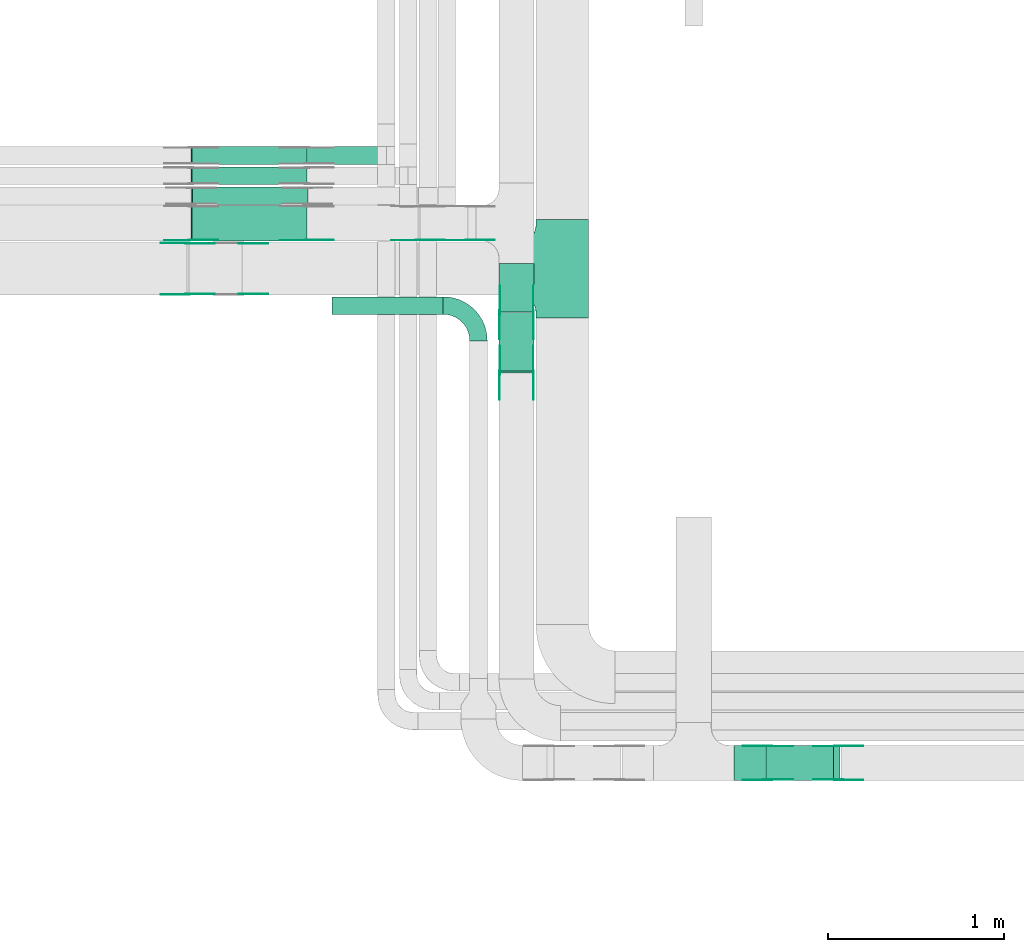
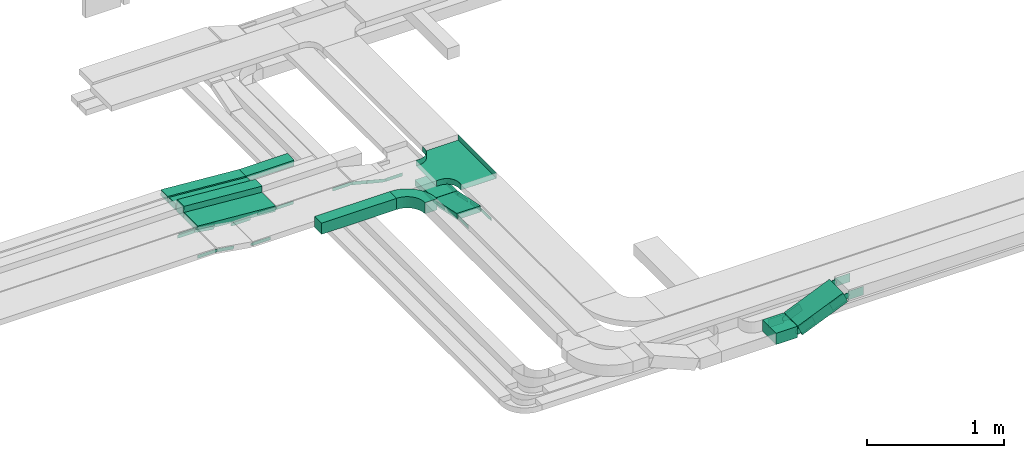
# One storey, part 4 of 19: 32 flow fittings, 10 flow segments.
"""IFC2X3 building model written with IfcOpenShell, lengths in millimetres."""

from ifc_helpers import new_model, entity, si_unit, converted_unit, derived_unit, direction, frame, frame_2d, origin, origin_2d_with_axis, place, context, subcontext, project, spatial, polyline, circle_curve, parameter, trimmed, segment, composite_curve, rectangle, outline, extrude, faceted_brep, source, transform, mapped, material, type_object, type_shapes, element, save


model = new_model("IFC2X3")

# Units and contexts
model_context = context("Model", 3, precision=0.01, world=origin(), true_north=direction((6.12303176911189e-17, 1.0)))
body_context = subcontext(model_context, "Body", "Model", "MODEL_VIEW")
ifc_project = project(units=[si_unit("LENGTHUNIT", "METRE", prefix="MILLI"), si_unit("AREAUNIT", "SQUARE_METRE"), si_unit("VOLUMEUNIT", "CUBIC_METRE"), converted_unit("PLANEANGLEUNIT", "DEGREE", entity("IfcRatioMeasure", 0.0174532925199433), si_unit("PLANEANGLEUNIT", "RADIAN"), dimensions=[0, 0, 0, 0, 0, 0, 0]), si_unit("MASSUNIT", "GRAM", prefix="KILO"), derived_unit("MASSDENSITYUNIT", [(si_unit("MASSUNIT", "GRAM", prefix="KILO"), 1), (si_unit("LENGTHUNIT", "METRE"), -3)]), derived_unit("MOMENTOFINERTIAUNIT", [(si_unit("LENGTHUNIT", "METRE"), 4)]), si_unit("TIMEUNIT", "SECOND"), si_unit("FREQUENCYUNIT", "HERTZ"), si_unit("THERMODYNAMICTEMPERATUREUNIT", "DEGREE_CELSIUS"), derived_unit("THERMALTRANSMITTANCEUNIT", [(si_unit("MASSUNIT", "GRAM", prefix="KILO"), 1), (si_unit("THERMODYNAMICTEMPERATUREUNIT", "KELVIN"), -1), (si_unit("TIMEUNIT", "SECOND"), -3)]), derived_unit("VOLUMETRICFLOWRATEUNIT", [(si_unit("LENGTHUNIT", "METRE"), 3), (si_unit("TIMEUNIT", "SECOND"), -1)]), derived_unit("MASSFLOWRATEUNIT", [(si_unit("MASSUNIT", "GRAM", prefix="KILO"), 1), (si_unit("TIMEUNIT", "SECOND"), -1)]), derived_unit("ROTATIONALFREQUENCYUNIT", [(si_unit("TIMEUNIT", "SECOND"), -1)]), si_unit("ELECTRICCURRENTUNIT", "AMPERE"), si_unit("ELECTRICVOLTAGEUNIT", "VOLT"), si_unit("POWERUNIT", "WATT"), si_unit("FORCEUNIT", "NEWTON", prefix="KILO"), si_unit("ILLUMINANCEUNIT", "LUX"), si_unit("LUMINOUSFLUXUNIT", "LUMEN"), si_unit("LUMINOUSINTENSITYUNIT", "CANDELA"), derived_unit("USERDEFINED", [(si_unit("MASSUNIT", "GRAM", prefix="KILO"), -1), (si_unit("LENGTHUNIT", "METRE"), -2), (si_unit("TIMEUNIT", "SECOND"), 3), (si_unit("LUMINOUSFLUXUNIT", "LUMEN"), 1)]), derived_unit("LINEARVELOCITYUNIT", [(si_unit("LENGTHUNIT", "METRE"), 1), (si_unit("TIMEUNIT", "SECOND"), -1)]), si_unit("PRESSUREUNIT", "PASCAL"), derived_unit("USERDEFINED", [(si_unit("LENGTHUNIT", "METRE"), -2), (si_unit("MASSUNIT", "GRAM", prefix="KILO"), 1), (si_unit("TIMEUNIT", "SECOND"), -2)]), derived_unit("LINEARFORCEUNIT", [(si_unit("MASSUNIT", "GRAM", prefix="KILO"), 1), (si_unit("LENGTHUNIT", "METRE"), 1), (si_unit("TIMEUNIT", "SECOND"), -2), (si_unit("LENGTHUNIT", "METRE"), -1)]), derived_unit("PLANARFORCEUNIT", [(si_unit("MASSUNIT", "GRAM", prefix="KILO"), 1), (si_unit("LENGTHUNIT", "METRE"), 1), (si_unit("TIMEUNIT", "SECOND"), -2), (si_unit("LENGTHUNIT", "METRE"), -2)])], contexts=[model_context])

# Site, building, storey
site_placement = place(None, origin())
site = spatial("IfcSite", under=ifc_project, at=site_placement, CompositionType="ELEMENT")
building_placement = place(site_placement, origin())
building = spatial("IfcBuilding", under=site, at=building_placement, CompositionType="ELEMENT")
storey_placement = place(building_placement, frame((0.0, 0.0, 12000.0)))
storey = spatial("IfcBuildingStorey", under=building, at=storey_placement, CompositionType="ELEMENT", Elevation=12000.0)

# Flow segments
cable_carrier_segment_type = type_object("IfcCableCarrierSegmentType", PredefinedType="CABLETRAYSEGMENT")
flow_segment_1_placement = place(storey_placement, frame((16927.61, 12994.16, 2800.0)))
element("IfcFlowSegment", 1, at=flow_segment_1_placement, inside=storey, type_object=cable_carrier_segment_type, context=body_context, shape_type="SweptSolid", body=[
    extrude(rectangle(XDim=404.371545128235, YDim=99.9999999999989, at=origin_2d_with_axis()), frame((202.19, 50.0, 0.0), z_axis=(0.0, 0.0, 1.0), x_axis=(-1.0, 0.0, 0.0)), (0.0, 0.0, 1.0), 50.0000000000038),
])
flow_segment_2_placement = place(storey_placement, frame((18018.59, 12154.97, 2727.85)))
element("IfcFlowSegment", 2, at=flow_segment_2_placement, inside=storey, type_object=cable_carrier_segment_type, context=body_context, shape_type="SweptSolid", body=[
    extrude(rectangle(XDim=273.824636449433, YDim=199.999999999998, at=origin_2d_with_axis()), frame((100.0, 136.91, 0.0), z_axis=(0.0, 0.0, 1.0), x_axis=(0.0, -1.0, 0.0)), (0.0, 0.0, 1.0), 50.0000000000016),
])
flow_segment_3_placement = place(storey_placement, frame((18018.59, 11806.46, 2729.24)))
element("IfcFlowSegment", 3, at=flow_segment_3_placement, inside=storey, type_object=cable_carrier_segment_type, context=body_context, shape_type="SweptSolid", body=[
    extrude(rectangle(XDim=50.0000000000024, YDim=342.797863451643, at=frame_2d((0.0, 0.0), x_axis=(0.0, 1.0))), frame((0.0, 172.85, 60.09), z_axis=(1.0, 0.0, 0.0), x_axis=(0.0, -0.978147600734828, 0.207911690812948)), (0.0, 0.0, 1.0), 199.999999999998),
])
flow_segment_4_placement = place(storey_placement, frame((19539.18, 9487.45, 2637.31)))
element("IfcFlowSegment", 4, at=flow_segment_4_placement, inside=storey, type_object=cable_carrier_segment_type, context=body_context, shape_type="SweptSolid", body=[
    extrude(rectangle(XDim=100.000000000001, YDim=200.0, at=origin_2d_with_axis()), frame((19.54, 100.0, 46.03), z_axis=(0.920504853454354, 0.0, 0.390731128484766), x_axis=(-0.390731128484766, 0.0, 0.920504853454354)), (0.0, 0.0, 1.0), 414.563208392916),
])
flow_segment_5_placement = place(storey_placement, frame((19356.52, 9487.45, 2628.65)))
element("IfcFlowSegment", 5, at=flow_segment_5_placement, inside=storey, type_object=cable_carrier_segment_type, context=body_context, shape_type="SweptSolid", body=[
    extrude(rectangle(XDim=179.180863906, YDim=200.0, at=origin_2d_with_axis()), frame((89.59, 100.0, 0.0), z_axis=(0.0, 0.0, 1.0), x_axis=(-1.0, 0.0, 0.0)), (0.0, 0.0, 1.0), 99.9999999999989),
])
flow_segment_6_placement = place(storey_placement, frame((17069.22, 12140.4, 2800.0)))
element("IfcFlowSegment", 6, at=flow_segment_6_placement, inside=storey, type_object=cable_carrier_segment_type, context=body_context, shape_type="SweptSolid", body=[
    extrude(rectangle(XDim=631.454921335267, YDim=99.9999999999989, at=origin_2d_with_axis()), frame((315.73, 50.0, 0.0), z_axis=(0.0, 0.0, 1.0), x_axis=(-1.0, 0.0, 0.0)), (0.0, 0.0, 1.0), 99.9999999999989),
])
flow_segment_7_placement = place(storey_placement, frame((16266.55, 12994.16, 2800.23)))
element("IfcFlowSegment", 7, at=flow_segment_7_placement, inside=storey, type_object=cable_carrier_segment_type, context=body_context, shape_type="SweptSolid", body=[
    extrude(rectangle(XDim=50.0, YDim=99.9999999999989, at=frame_2d((0.0, 0.0), x_axis=(0.0, 1.0))), frame((1.89, 50.0, 74.61), z_axis=(0.997135526115965, 0.0, -0.0756355905472889), x_axis=(0.0, 1.0, 0.0)), (0.0, 0.0, 1.0), 656.867870987157),
])
flow_segment_8_placement = place(storey_placement, frame((16266.55, 12879.44, 2800.23)))
element("IfcFlowSegment", 8, at=flow_segment_8_placement, inside=storey, type_object=cable_carrier_segment_type, context=body_context, shape_type="SweptSolid", body=[
    extrude(rectangle(XDim=49.9999999999998, YDim=99.9999999999989, at=frame_2d((0.0, 0.0), x_axis=(0.0, 1.0))), frame((1.89, 50.0, 74.61), z_axis=(0.997135526115969, 0.0, -0.0756355905472458), x_axis=(0.0, 1.0, 0.0)), (0.0, 0.0, 1.0), 656.867870987572),
])
flow_segment_9_placement = place(storey_placement, frame((16265.6, 12764.16, 2800.09)))
element("IfcFlowSegment", 9, at=flow_segment_9_placement, inside=storey, type_object=cable_carrier_segment_type, context=body_context, shape_type="SweptSolid", body=[
    extrude(rectangle(XDim=99.9999999999997, YDim=99.9999999999989, at=frame_2d((0.0, 0.0), x_axis=(0.0, 1.0))), frame((3.78, 50.0, 99.68), z_axis=(0.997135526115969, 0.0, -0.0756355905472458), x_axis=(0.0, 1.0, 0.0)), (0.0, 0.0, 1.0), 658.757464019453),
])
flow_segment_10_placement = place(storey_placement, frame((16266.55, 12558.8, 2800.23)))
element("IfcFlowSegment", 10, at=flow_segment_10_placement, inside=storey, type_object=cable_carrier_segment_type, context=body_context, shape_type="SweptSolid", body=[
    extrude(rectangle(XDim=50.0, YDim=199.999999999998, at=frame_2d((0.0, 0.0), x_axis=(0.0, 1.0))), frame((1.89, 100.0, 74.61), z_axis=(0.997135526115965, 0.0, -0.0756355905472889), x_axis=(0.0, 1.0, 0.0)), (0.0, 0.0, 1.0), 656.867870987322),
])

# Flow fittings
ifc_material_1 = material()
cable_carrier_fitting_type_1 = type_object("IfcCableCarrierFittingType", PredefinedType="NOTDEFINED", material=ifc_material_1)
shared_shape_1 = source(origin(), body_context, "Body", "Brep", [
    faceted_brep([(-153.41, -224.12, 25.0), (-150.0, -250.0, 25.0), (-150.0, -280.0, 25.0), (-149.2, -280.0, 25.0), (-149.2, -250.0, 25.0), (-152.63, -223.91, 25.0), (-162.7, -199.6, 25.0), (-178.72, -178.72, 25.0), (-199.6, -162.7, 25.0), (-223.91, -152.63, 25.0), (-250.0, -149.2, 25.0), (-280.0, -149.2, 25.0), (-280.0, -150.0, 25.0), (-250.0, -150.0, 25.0), (-224.12, -153.41, 25.0), (-200.0, -163.4, 25.0), (-179.29, -179.29, 25.0), (-163.4, -200.0, 25.0), (280.0, -150.0, 25.0), (280.0, -149.2, 25.0), (250.0, -149.2, 25.0), (223.91, -152.63, 25.0), (199.6, -162.7, 25.0), (178.72, -178.72, 25.0), (162.7, -199.6, 25.0), (152.63, -223.91, 25.0), (149.2, -250.0, 25.0), (149.2, -280.0, 25.0), (150.0, -280.0, 25.0), (150.0, -250.0, 25.0), (153.41, -224.12, 25.0), (163.4, -200.0, 25.0), (179.29, -179.29, 25.0), (200.0, -163.4, 25.0), (224.12, -153.41, 25.0), (250.0, -150.0, 25.0), (280.0, 149.2, 25.0), (280.0, 150.0, 25.0), (-280.0, 150.0, 25.0), (-280.0, 149.2, 25.0), (-280.0, -150.0, -25.0), (-280.0, 150.0, -25.0), (280.0, 150.0, -25.0), (280.0, -150.0, -25.0), (250.0, -150.0, -25.0), (224.12, -153.41, -25.0), (200.0, -163.4, -25.0), (179.29, -179.29, -25.0), (163.4, -200.0, -25.0), (153.41, -224.12, -25.0), (150.0, -250.0, -25.0), (150.0, -280.0, -25.0), (-150.0, -280.0, -25.0), (-150.0, -250.0, -25.0), (-153.41, -224.12, -25.0), (-163.4, -200.0, -25.0), (-179.29, -179.29, -25.0), (-200.0, -163.4, -25.0), (-224.12, -153.41, -25.0), (-250.0, -150.0, -25.0), (-150.0, -250.0, -24.2), (149.2, -280.0, -24.2), (-149.2, -280.0, -24.2), (-149.2, -250.0, -24.2), (-250.0, -149.2, -24.2), (-280.0, -149.2, -24.2), (280.0, -149.2, -24.2), (250.0, -149.2, -24.2), (-280.0, 149.2, -24.2), (-250.0, -150.0, -24.2), (250.0, -150.0, -24.2), (280.0, 149.2, -24.2), (149.2, -250.0, -24.2), (150.0, -250.0, -24.2), (-223.91, -152.63, -24.2), (-199.6, -162.7, -24.2), (-178.72, -178.72, -24.2), (-162.7, -199.6, -24.2), (-152.63, -223.91, -24.2), (152.63, -223.91, -24.2), (162.7, -199.6, -24.2), (178.72, -178.72, -24.2), (199.6, -162.7, -24.2), (223.91, -152.63, -24.2)], [[[0, 1, 2, 3, 4, 5, 6, 7, 8, 9, 10, 11, 12, 13, 14, 15, 16, 17]], [[18, 19, 20, 21, 22, 23, 24, 25, 26, 27, 28, 29, 30, 31, 32, 33, 34, 35]], [[36, 37, 38, 39]], [[40, 41, 42, 43, 44, 45, 46, 47, 48, 49, 50, 51, 52, 53, 54, 55, 56, 57, 58, 59]], [[2, 1, 60, 53, 52]], [[3, 2, 52, 51, 28, 27, 61, 62]], [[4, 3, 62, 63]], [[11, 10, 64, 65]], [[20, 19, 66, 67]], [[39, 38, 41, 40, 12, 11, 65, 68]], [[13, 12, 40, 59, 69]], [[18, 35, 70, 44, 43]], [[19, 18, 43, 42, 37, 36, 71, 66]], [[27, 26, 72, 61]], [[29, 28, 51, 50, 73]], [[38, 37, 42, 41]], [[36, 39, 68, 71]], [[68, 65, 64, 74, 75, 76, 77, 78, 63, 62, 61, 72, 79, 80, 81, 82, 83, 67, 66, 71]], [[14, 13, 69, 59, 58]], [[58, 57, 15, 14]], [[15, 57, 56, 16]], [[0, 17, 55, 54]], [[0, 54, 53, 60, 1]], [[55, 17, 16, 56]], [[5, 4, 63, 78]], [[6, 5, 78, 77]], [[7, 6, 77, 76]], [[8, 7, 76, 75]], [[9, 8, 75, 74]], [[10, 9, 74, 64]], [[21, 20, 67, 83]], [[22, 21, 83, 82]], [[23, 22, 82, 81]], [[81, 80, 24, 23]], [[24, 80, 79, 25]], [[79, 72, 26, 25]], [[30, 29, 73, 50, 49]], [[31, 30, 49, 48]], [[31, 48, 47, 32]], [[33, 32, 47, 46]], [[45, 34, 33, 46]], [[34, 45, 44, 70, 35]]]),
])
type_shapes(cable_carrier_fitting_type_1, [shared_shape_1])
flow_fitting_1_placement = place(storey_placement, frame((18378.54, 12399.79, 2825.0), z_axis=(0.0, 0.0, 1.0), x_axis=(0.0, -1.0, 0.0)))
element("IfcFlowFitting", 11, at=flow_fitting_1_placement, inside=storey, type_object=cable_carrier_fitting_type_1, material=ifc_material_1, Name="470_DKC_S5_T", context=body_context, shape_type="MappedRepresentation", body=[
    mapped(shared_shape_1, transform((0.0, 0.0, 0.0), scale=1.0)),
])
ifc_material_2 = material(Name="G")
cable_carrier_fitting_type_2 = type_object("IfcCableCarrierFittingType", PredefinedType="NOTDEFINED", material=ifc_material_2)
shared_shape_2 = source(origin(), body_context, "Body", "SweptSolid", [
    extrude(outline(composite_curve([segment(trimmed(circle_curve(frame_2d((-44.59, 0.0), x_axis=(1.0, 0.0)), 12.5), [parameter(90.0000000000007)], [parameter(270.0)], True, "PARAMETER"), True, "CONTINUOUS"), segment(polyline([(-44.59, -12.5), (-33.09, -12.5)]), True, "CONTINUOUS"), segment(polyline([(-33.09, -12.5), (-31.23, -14.5)]), True, "CONTINUOUS"), segment(polyline([(-31.23, -14.5), (108.91, -14.5)]), True, "CONTINUOUS"), segment(polyline([(108.91, -14.5), (108.91, 14.5)]), True, "CONTINUOUS"), segment(polyline([(108.91, 14.5), (-31.23, 14.5)]), True, "CONTINUOUS"), segment(polyline([(-31.23, 14.5), (-33.09, 12.5)]), True, "CONTINUOUS"), segment(polyline([(-33.09, 12.5), (-44.59, 12.5)]), True, "CONTINUOUS")], self_intersect=False)), frame((44.59, 0.0, 0.0), z_axis=(0.0, 0.0, -1.0), x_axis=(1.0, 0.0, 0.0)), (0.0, 0.0, -1.0), 2.0),
])
type_shapes(cable_carrier_fitting_type_2, [shared_shape_2])
flow_fitting_2_placement = place(storey_placement, frame((18023.13, 12150.92, 2752.85), z_axis=(-1.0, 0.0, 0.0), x_axis=(0.0, -0.978147600733805, 0.207911690817761)))
element("IfcFlowFitting", 12, at=flow_fitting_2_placement, inside=storey, type_object=cable_carrier_fitting_type_2, material=ifc_material_2, context=body_context, shape_type="MappedRepresentation", body=[
    mapped(shared_shape_2, transform((0.0, 0.0, 0.0), scale=1.0)),
])
cable_carrier_fitting_type_3 = type_object("IfcCableCarrierFittingType", PredefinedType="NOTDEFINED", material=ifc_material_2)
type_shapes(cable_carrier_fitting_type_3, [shared_shape_2])
flow_fitting_3_placement = place(storey_placement, frame((18212.05, 12150.92, 2752.85), z_axis=(1.0, 0.0, 0.0), x_axis=(0.0, 1.0, 0.0)))
element("IfcFlowFitting", 13, at=flow_fitting_3_placement, inside=storey, type_object=cable_carrier_fitting_type_3, material=ifc_material_2, context=body_context, shape_type="MappedRepresentation", body=[
    mapped(shared_shape_2, transform((0.0, 0.0, 0.0), scale=1.0)),
])
flow_fitting_4_placement = place(storey_placement, frame((18214.05, 11807.7, 2825.81), z_axis=(1.0, 0.0, 0.0), x_axis=(0.0, -1.0, 0.0)))
element("IfcFlowFitting", 14, at=flow_fitting_4_placement, inside=storey, type_object=cable_carrier_fitting_type_2, material=ifc_material_2, context=body_context, shape_type="MappedRepresentation", body=[
    mapped(shared_shape_2, transform((0.0, 0.0, 0.0), scale=1.0)),
])
for number, where, z_axis, x_axis in (
    (15, (18025.13, 11807.7, 2825.81), (-1.0, 0.0, 0.0), (0.0, 0.978147600733806, -0.207911690817758)),
    (16, (16550.94, 12256.33, 2825.0), (0.0, -1.0, 0.0), (1.0, 0.0, 0.0)),
):
    element("IfcFlowFitting", number, at=place(storey_placement, frame(where, z_axis=z_axis, x_axis=x_axis)), inside=storey, type_object=cable_carrier_fitting_type_3, material=ifc_material_2, context=body_context, shape_type="MappedRepresentation", body=[
        mapped(shared_shape_2, transform((0.0, 0.0, 0.0), scale=1.0)),
    ])
flow_fitting_5_placement = place(storey_placement, frame((16245.69, 12254.33, 2875.0), z_axis=(0.0, -1.0, 0.0), x_axis=(-1.0, 0.0, 0.0)))
element("IfcFlowFitting", 17, at=flow_fitting_5_placement, inside=storey, type_object=cable_carrier_fitting_type_2, material=ifc_material_2, context=body_context, shape_type="MappedRepresentation", body=[
    mapped(shared_shape_2, transform((0.0, 0.0, 0.0), scale=1.0)),
])
for number, where, z_axis, x_axis in (
    (18, (16245.69, 12543.25, 2875.0), (0.0, 1.0, 0.0), (0.986849163973514, 0.0, -0.161643829343333)),
    (19, (16925.52, 12565.34, 2825.0), (0.0, -1.0, 0.0), (1.0, 0.0, 0.0)),
):
    element("IfcFlowFitting", number, at=place(storey_placement, frame(where, z_axis=z_axis, x_axis=x_axis)), inside=storey, type_object=cable_carrier_fitting_type_3, material=ifc_material_2, context=body_context, shape_type="MappedRepresentation", body=[
        mapped(shared_shape_2, transform((0.0, 0.0, 0.0), scale=1.0)),
    ])
flow_fitting_6_placement = place(storey_placement, frame((16266.34, 12563.34, 2875.0), z_axis=(0.0, -1.0, 0.0), x_axis=(-1.0, 0.0, 0.0)))
element("IfcFlowFitting", 20, at=flow_fitting_6_placement, inside=storey, type_object=cable_carrier_fitting_type_2, material=ifc_material_2, context=body_context, shape_type="MappedRepresentation", body=[
    mapped(shared_shape_2, transform((0.0, 0.0, 0.0), scale=1.0)),
])
flow_fitting_7_placement = place(storey_placement, frame((17841.16, 12565.34, 2752.85), z_axis=(0.0, -1.0, 0.0), x_axis=(1.0, 0.0, 0.0)))
element("IfcFlowFitting", 21, at=flow_fitting_7_placement, inside=storey, type_object=cable_carrier_fitting_type_3, material=ifc_material_2, context=body_context, shape_type="MappedRepresentation", body=[
    mapped(shared_shape_2, transform((0.0, 0.0, 0.0), scale=1.0)),
])
flow_fitting_8_placement = place(storey_placement, frame((17557.78, 12563.34, 2825.0), z_axis=(0.0, -1.0, 0.0), x_axis=(-1.0, 0.0, 0.0)))
element("IfcFlowFitting", 22, at=flow_fitting_8_placement, inside=storey, type_object=cable_carrier_fitting_type_2, material=ifc_material_2, context=body_context, shape_type="MappedRepresentation", body=[
    mapped(shared_shape_2, transform((0.0, 0.0, 0.0), scale=1.0)),
])
cable_carrier_fitting_type_4 = type_object("IfcCableCarrierFittingType", PredefinedType="NOTDEFINED", material=ifc_material_2)
shared_shape_3 = source(origin(), body_context, "Body", "SweptSolid", [
    extrude(outline(composite_curve([segment(trimmed(circle_curve(frame_2d((-44.59, 0.0), x_axis=(1.0, 0.0)), 12.5), [parameter(90.0000000000007)], [parameter(270.0)], True, "PARAMETER"), True, "CONTINUOUS"), segment(polyline([(-44.59, -12.5), (-33.09, -12.5)]), True, "CONTINUOUS"), segment(polyline([(-33.09, -12.5), (-31.23, -14.5)]), True, "CONTINUOUS"), segment(polyline([(-31.23, -14.5), (108.91, -14.5)]), True, "CONTINUOUS"), segment(polyline([(108.91, -14.5), (108.91, 14.5)]), True, "CONTINUOUS"), segment(polyline([(108.91, 14.5), (-31.23, 14.5)]), True, "CONTINUOUS"), segment(polyline([(-31.23, 14.5), (-33.09, 12.5)]), True, "CONTINUOUS"), segment(polyline([(-33.09, 12.5), (-44.59, 12.5)]), True, "CONTINUOUS")], self_intersect=False)), frame((44.59, 0.0, 0.0)), (0.0, 0.0, 1.0), 2.0),
])
type_shapes(cable_carrier_fitting_type_4, [shared_shape_3])
flow_fitting_9_placement = place(storey_placement, frame((18214.05, 12150.92, 2752.85), z_axis=(1.0, 0.0, 0.0), x_axis=(0.0, -0.978147600733805, 0.207911690817761)))
element("IfcFlowFitting", 23, at=flow_fitting_9_placement, inside=storey, type_object=cable_carrier_fitting_type_4, material=ifc_material_2, context=body_context, shape_type="MappedRepresentation", body=[
    mapped(shared_shape_3, transform((0.0, 0.0, 0.0), scale=1.0)),
])
cable_carrier_fitting_type_5 = type_object("IfcCableCarrierFittingType", PredefinedType="NOTDEFINED", material=ifc_material_2)
type_shapes(cable_carrier_fitting_type_5, [shared_shape_3])
flow_fitting_10_placement = place(storey_placement, frame((18025.13, 12150.92, 2752.85), z_axis=(-1.0, 0.0, 0.0), x_axis=(0.0, 1.0, 0.0)))
element("IfcFlowFitting", 24, at=flow_fitting_10_placement, inside=storey, type_object=cable_carrier_fitting_type_5, material=ifc_material_2, context=body_context, shape_type="MappedRepresentation", body=[
    mapped(shared_shape_3, transform((0.0, 0.0, 0.0), scale=1.0)),
])
flow_fitting_11_placement = place(storey_placement, frame((18023.13, 11807.7, 2825.81), z_axis=(-1.0, 0.0, 0.0), x_axis=(0.0, -1.0, 0.0)))
element("IfcFlowFitting", 25, at=flow_fitting_11_placement, inside=storey, type_object=cable_carrier_fitting_type_4, material=ifc_material_2, context=body_context, shape_type="MappedRepresentation", body=[
    mapped(shared_shape_3, transform((0.0, 0.0, 0.0), scale=1.0)),
])
for number, where, z_axis, x_axis in (
    (26, (18212.05, 11807.7, 2825.81), (1.0, 0.0, 0.0), (0.0, 0.978147600733806, -0.207911690817758)),
    (27, (16550.94, 12543.25, 2825.0), (0.0, 1.0, 0.0), (1.0, 0.0, 0.0)),
):
    element("IfcFlowFitting", number, at=place(storey_placement, frame(where, z_axis=z_axis, x_axis=x_axis)), inside=storey, type_object=cable_carrier_fitting_type_5, material=ifc_material_2, context=body_context, shape_type="MappedRepresentation", body=[
        mapped(shared_shape_3, transform((0.0, 0.0, 0.0), scale=1.0)),
    ])
flow_fitting_12_placement = place(storey_placement, frame((16245.69, 12545.25, 2875.0), z_axis=(0.0, 1.0, 0.0), x_axis=(-1.0, 0.0, 0.0)))
element("IfcFlowFitting", 28, at=flow_fitting_12_placement, inside=storey, type_object=cable_carrier_fitting_type_4, material=ifc_material_2, context=body_context, shape_type="MappedRepresentation", body=[
    mapped(shared_shape_3, transform((0.0, 0.0, 0.0), scale=1.0)),
])
flow_fitting_13_placement = place(storey_placement, frame((16245.69, 12256.33, 2875.0), z_axis=(0.0, -1.0, 0.0), x_axis=(0.986849163973514, 0.0, -0.161643829343333)))
element("IfcFlowFitting", 29, at=flow_fitting_13_placement, inside=storey, type_object=cable_carrier_fitting_type_5, material=ifc_material_2, context=body_context, shape_type="MappedRepresentation", body=[
    mapped(shared_shape_3, transform((0.0, 0.0, 0.0), scale=1.0)),
])
flow_fitting_14_placement = place(storey_placement, frame((16925.52, 12563.34, 2825.0), z_axis=(0.0, -1.0, 0.0), x_axis=(-0.997135526115969, 0.0, 0.0756355905472349)))
element("IfcFlowFitting", 30, at=flow_fitting_14_placement, inside=storey, type_object=cable_carrier_fitting_type_4, material=ifc_material_2, context=body_context, shape_type="MappedRepresentation", body=[
    mapped(shared_shape_3, transform((0.0, 0.0, 0.0), scale=1.0)),
])
flow_fitting_15_placement = place(storey_placement, frame((16266.34, 12565.34, 2875.0), z_axis=(0.0, -1.0, 0.0), x_axis=(0.99713552611597, 0.0, -0.0756355905472288)))
element("IfcFlowFitting", 31, at=flow_fitting_15_placement, inside=storey, type_object=cable_carrier_fitting_type_5, material=ifc_material_2, context=body_context, shape_type="MappedRepresentation", body=[
    mapped(shared_shape_3, transform((0.0, 0.0, 0.0), scale=1.0)),
])
flow_fitting_16_placement = place(storey_placement, frame((17841.16, 12563.34, 2752.85), z_axis=(0.0, -1.0, 0.0), x_axis=(-0.969084530600981, 0.0, 0.246728945504732)))
element("IfcFlowFitting", 32, at=flow_fitting_16_placement, inside=storey, type_object=cable_carrier_fitting_type_4, material=ifc_material_2, context=body_context, shape_type="MappedRepresentation", body=[
    mapped(shared_shape_3, transform((0.0, 0.0, 0.0), scale=1.0)),
])
flow_fitting_17_placement = place(storey_placement, frame((17557.78, 12565.34, 2825.0), z_axis=(0.0, -1.0, 0.0), x_axis=(0.96908453060098, 0.0, -0.246728945504733)))
element("IfcFlowFitting", 33, at=flow_fitting_17_placement, inside=storey, type_object=cable_carrier_fitting_type_5, material=ifc_material_2, context=body_context, shape_type="MappedRepresentation", body=[
    mapped(shared_shape_3, transform((0.0, 0.0, 0.0), scale=1.0)),
])
cable_carrier_fitting_type_6 = type_object("IfcCableCarrierFittingType", Name="470_DKC_S5_Variable Angle Elbow 0-45:-", PredefinedType="NOTDEFINED", material=ifc_material_1)
shared_shape_4 = source(origin(), body_context, "Body", "SweptSolid", [
    extrude(outline(composite_curve([segment(polyline([(-100.75, -150.25), (-99.75, -150.25)]), True, "CONTINUOUS"), segment(trimmed(circle_curve(frame_2d((-99.75, 99.75), x_axis=(0.0, -1.0)), 250.0), [parameter(0.0)], [parameter(90.0000000000001)], True, "PARAMETER"), True, "CONTINUOUS"), segment(polyline([(150.25, 99.75), (150.25, 100.75)]), True, "CONTINUOUS"), segment(polyline([(150.25, 100.75), (50.25, 100.75)]), True, "CONTINUOUS"), segment(polyline([(50.25, 100.75), (50.25, 99.75)]), True, "CONTINUOUS"), segment(trimmed(circle_curve(frame_2d((-99.75, 99.75), x_axis=(0.0, -1.0)), 150.0), [parameter(0.0)], [parameter(90.0000000000001)], True, "PARAMETER"), False, "CONTINUOUS"), segment(polyline([(-99.75, -50.25), (-100.75, -50.25)]), True, "CONTINUOUS"), segment(polyline([(-100.75, -50.25), (-100.75, -150.25)]), True, "CONTINUOUS")], self_intersect=False)), frame((-100.25, 100.25, -50.0)), (0.0, 0.0, 1.0), 100.0),
])
type_shapes(cable_carrier_fitting_type_6, [shared_shape_4])
flow_fitting_18_placement = place(storey_placement, frame((17901.67, 12190.4, 2850.0), z_axis=(0.0, 0.0, 1.0), x_axis=(0.0, 1.0, 0.0)))
element("IfcFlowFitting", 34, at=flow_fitting_18_placement, inside=storey, type_object=cable_carrier_fitting_type_6, material=ifc_material_1, Name="470_DKC_S5_Variable Angle Elbow 0-45:-", ObjectType="470_DKC_S5_Variable Angle Elbow 0-45:-", context=body_context, shape_type="MappedRepresentation", body=[
    mapped(shared_shape_4, transform((0.0, 0.0, 0.0), scale=1.0)),
])
cable_carrier_fitting_type_7 = type_object("IfcCableCarrierFittingType", PredefinedType="NOTDEFINED", material=ifc_material_2)
shared_shape_5 = source(origin(), body_context, "Body", "SweptSolid", [
    extrude(outline(composite_curve([segment(trimmed(circle_curve(frame_2d((-41.47, 0.0), x_axis=(1.0, 0.0)), 25.0), [parameter(90.0000000000007)], [parameter(270.0)], True, "PARAMETER"), True, "CONTINUOUS"), segment(polyline([(-41.47, -25.0), (-29.97, -25.0)]), True, "CONTINUOUS"), segment(polyline([(-29.97, -25.0), (-28.1, -38.5)]), True, "CONTINUOUS"), segment(polyline([(-28.1, -38.5), (99.53, -38.5)]), True, "CONTINUOUS"), segment(polyline([(99.53, -38.5), (99.53, 38.5)]), True, "CONTINUOUS"), segment(polyline([(99.53, 38.5), (-28.1, 38.5)]), True, "CONTINUOUS"), segment(polyline([(-28.1, 38.5), (-29.97, 25.0)]), True, "CONTINUOUS"), segment(polyline([(-29.97, 25.0), (-41.47, 25.0)]), True, "CONTINUOUS")], self_intersect=False)), frame((41.47, 0.0, 0.0), z_axis=(0.0, 0.0, -1.0), x_axis=(1.0, 0.0, 0.0)), (0.0, 0.0, -1.0), 2.0),
])
type_shapes(cable_carrier_fitting_type_7, [shared_shape_5])
flow_fitting_19_placement = place(storey_placement, frame((19547.68, 9682.91, 2678.65), z_axis=(0.0, 1.0, 0.0), x_axis=(-1.0, 0.0, 0.0)))
element("IfcFlowFitting", 35, at=flow_fitting_19_placement, inside=storey, type_object=cable_carrier_fitting_type_7, material=ifc_material_2, context=body_context, shape_type="MappedRepresentation", body=[
    mapped(shared_shape_5, transform((0.0, 0.0, 0.0), scale=1.0)),
])
cable_carrier_fitting_type_8 = type_object("IfcCableCarrierFittingType", PredefinedType="NOTDEFINED", material=ifc_material_2)
type_shapes(cable_carrier_fitting_type_8, [shared_shape_5])
flow_fitting_20_placement = place(storey_placement, frame((19547.68, 9493.99, 2678.65), z_axis=(0.0, -1.0, 0.0), x_axis=(0.920504853452433, 0.0, 0.390731128489292)))
element("IfcFlowFitting", 36, at=flow_fitting_20_placement, inside=storey, type_object=cable_carrier_fitting_type_8, material=ifc_material_2, context=body_context, shape_type="MappedRepresentation", body=[
    mapped(shared_shape_5, transform((0.0, 0.0, 0.0), scale=1.0)),
])
flow_fitting_21_placement = place(storey_placement, frame((19951.36, 9682.91, 2850.0), z_axis=(0.0, 1.0, 0.0), x_axis=(1.0, 0.0, 0.0)))
element("IfcFlowFitting", 37, at=flow_fitting_21_placement, inside=storey, type_object=cable_carrier_fitting_type_7, material=ifc_material_2, context=body_context, shape_type="MappedRepresentation", body=[
    mapped(shared_shape_5, transform((0.0, 0.0, 0.0), scale=1.0)),
])
flow_fitting_22_placement = place(storey_placement, frame((19951.36, 9493.99, 2850.0), z_axis=(0.0, -1.0, 0.0), x_axis=(-0.920504853454359, 0.0, -0.390731128484754)))
element("IfcFlowFitting", 38, at=flow_fitting_22_placement, inside=storey, type_object=cable_carrier_fitting_type_8, material=ifc_material_2, context=body_context, shape_type="MappedRepresentation", body=[
    mapped(shared_shape_5, transform((0.0, 0.0, 0.0), scale=1.0)),
])
cable_carrier_fitting_type_9 = type_object("IfcCableCarrierFittingType", PredefinedType="NOTDEFINED", material=ifc_material_2)
shared_shape_6 = source(origin(), body_context, "Body", "SweptSolid", [
    extrude(outline(composite_curve([segment(trimmed(circle_curve(frame_2d((-41.47, 0.0), x_axis=(1.0, 0.0)), 25.0), [parameter(90.0000000000007)], [parameter(270.0)], True, "PARAMETER"), True, "CONTINUOUS"), segment(polyline([(-41.47, -25.0), (-29.97, -25.0)]), True, "CONTINUOUS"), segment(polyline([(-29.97, -25.0), (-28.1, -38.5)]), True, "CONTINUOUS"), segment(polyline([(-28.1, -38.5), (99.53, -38.5)]), True, "CONTINUOUS"), segment(polyline([(99.53, -38.5), (99.53, 38.5)]), True, "CONTINUOUS"), segment(polyline([(99.53, 38.5), (-28.1, 38.5)]), True, "CONTINUOUS"), segment(polyline([(-28.1, 38.5), (-29.97, 25.0)]), True, "CONTINUOUS"), segment(polyline([(-29.97, 25.0), (-41.47, 25.0)]), True, "CONTINUOUS")], self_intersect=False)), frame((41.47, 0.0, 0.0)), (0.0, 0.0, 1.0), 2.0),
])
type_shapes(cable_carrier_fitting_type_9, [shared_shape_6])
flow_fitting_23_placement = place(storey_placement, frame((19547.68, 9491.99, 2678.65), z_axis=(0.0, -1.0, 0.0), x_axis=(-1.0, 0.0, 0.0)))
element("IfcFlowFitting", 39, at=flow_fitting_23_placement, inside=storey, type_object=cable_carrier_fitting_type_9, material=ifc_material_2, context=body_context, shape_type="MappedRepresentation", body=[
    mapped(shared_shape_6, transform((0.0, 0.0, 0.0), scale=1.0)),
])
cable_carrier_fitting_type_10 = type_object("IfcCableCarrierFittingType", PredefinedType="NOTDEFINED", material=ifc_material_2)
type_shapes(cable_carrier_fitting_type_10, [shared_shape_6])
flow_fitting_24_placement = place(storey_placement, frame((19547.68, 9680.91, 2678.65), z_axis=(0.0, 1.0, 0.0), x_axis=(0.920504853452433, 0.0, 0.390731128489292)))
element("IfcFlowFitting", 40, at=flow_fitting_24_placement, inside=storey, type_object=cable_carrier_fitting_type_10, material=ifc_material_2, context=body_context, shape_type="MappedRepresentation", body=[
    mapped(shared_shape_6, transform((0.0, 0.0, 0.0), scale=1.0)),
])
flow_fitting_25_placement = place(storey_placement, frame((19951.36, 9491.99, 2850.0), z_axis=(0.0, -1.0, 0.0), x_axis=(1.0, 0.0, 0.0)))
element("IfcFlowFitting", 41, at=flow_fitting_25_placement, inside=storey, type_object=cable_carrier_fitting_type_9, material=ifc_material_2, context=body_context, shape_type="MappedRepresentation", body=[
    mapped(shared_shape_6, transform((0.0, 0.0, 0.0), scale=1.0)),
])
flow_fitting_26_placement = place(storey_placement, frame((19951.36, 9680.91, 2850.0), z_axis=(0.0, 1.0, 0.0), x_axis=(-0.920504853454359, 0.0, -0.390731128484754)))
element("IfcFlowFitting", 42, at=flow_fitting_26_placement, inside=storey, type_object=cable_carrier_fitting_type_10, material=ifc_material_2, context=body_context, shape_type="MappedRepresentation", body=[
    mapped(shared_shape_6, transform((0.0, 0.0, 0.0), scale=1.0)),
])

save(model, "model.ifc")
